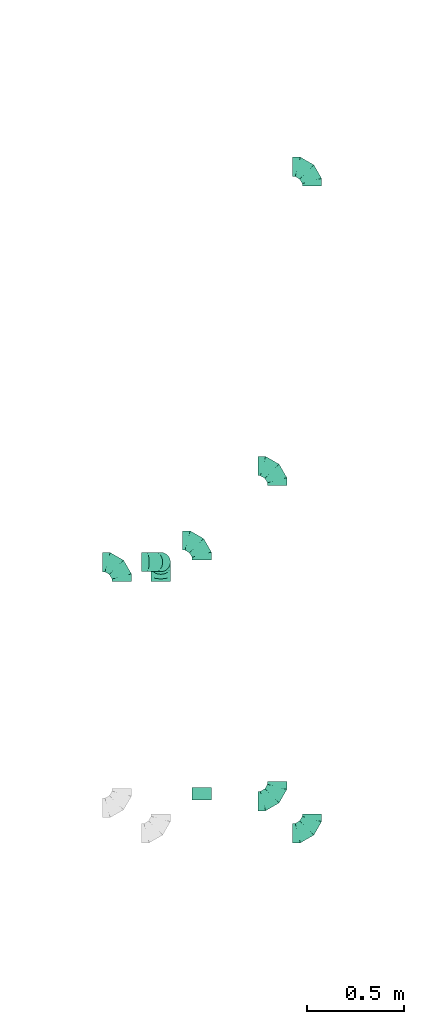
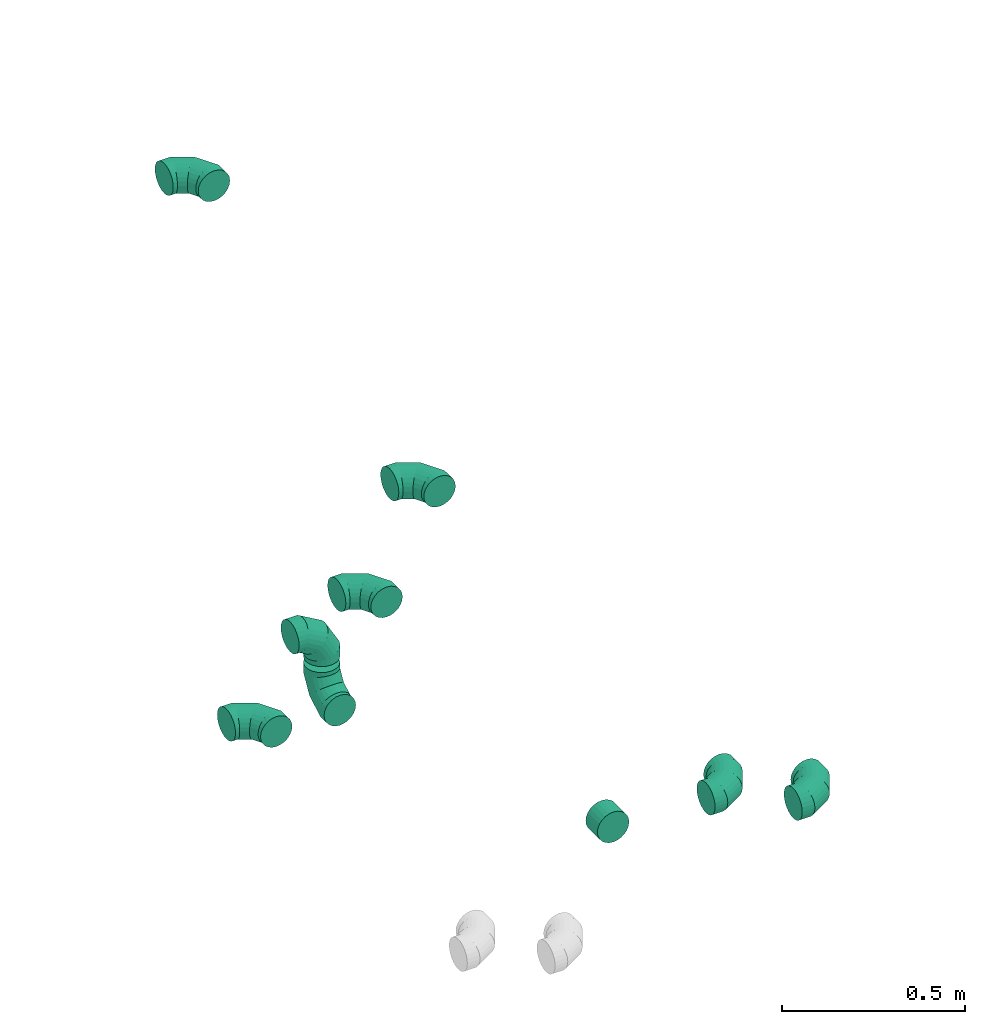
# One storey, part 28 of 32: 9 flow fittings.
"""IFC2X3 building model written with IfcOpenShell, lengths in millimetres."""

import ifcopenshell
import ifcopenshell.guid

model = None  # the IFC model being written
_history = None  # IfcOwnerHistory: only IFC2X3 demands one
_inside = {}  # id of a spatial element -> (the spatial element, [elements in it])
_under = {}  # id of a project, library or spatial element -> (it, [spatial elements below it])
_declared = {}  # id of a project -> (the project, [libraries it declares])
_typed = {}  # id of a type object -> (the type object, [elements of that type])
_made_of = {}  # id of a material, layer set ... -> (it, [elements and type objects made of it])


def new_model(schema):
    """Start an empty IFC model of exactly this schema.

    Asked for "IFC4X3", IfcOpenShell would pick the latest addendum, in which some entities
    have other attributes; the version numbers below select the first issue.
    IFC2X3 requires an IfcOwnerHistory on every rooted entity: one is made here for all.
    """
    global model, _history
    if schema == "IFC4X3":
        model = ifcopenshell.file(schema_version=(4, 3, 0, 0))
    else:
        model = ifcopenshell.file(schema=schema)
    _inside.clear()
    _under.clear()
    _declared.clear()
    _typed.clear()
    _made_of.clear()
    _history = None
    if model.schema == "IFC2X3":
        org = make("IfcOrganization", Name="unknown")
        user = make(
            "IfcPersonAndOrganization",
            ThePerson=make("IfcPerson", FamilyName="unknown"),
            TheOrganization=org,
        )
        app = make(
            "IfcApplication",
            ApplicationDeveloper=org,
            Version="unknown",
            ApplicationFullName="unknown",
            ApplicationIdentifier="unknown",
        )
        _history = make(
            "IfcOwnerHistory",
            OwningUser=user,
            OwningApplication=app,
            ChangeAction="ADDED",
            CreationDate=0,
        )
    return model


def make(cls, **values):
    """One entity of the class cls with the attributes given. An attribute that is None is left unset."""
    return model.create_entity(
        cls, **{name: value for name, value in values.items() if value is not None}
    )


def entity(cls, *values):
    """Any entity or typed value of the class cls, its attributes in the order of the schema. None: left unset."""
    e = model.create_entity(cls)
    for i, value in enumerate(values):
        if value is not None:
            e[i] = value
    return e


def rooted(cls, **values):
    """An entity with a GlobalId (a new one), such as an element, a storey or a relation."""
    return make(cls, GlobalId=ifcopenshell.guid.new(), OwnerHistory=_history, **values)


def si_unit(unit_type, name, prefix=None):
    """IfcSIUnit, for example si_unit("LENGTHUNIT", "METRE", prefix="MILLI")."""
    return make("IfcSIUnit", UnitType=unit_type, Prefix=prefix, Name=name)


def converted_unit(unit_type, name, factor, base, dimensions=None, offset=None):
    """IfcConversionBasedUnit, such as the inch: factor (a typed value) times the base unit."""
    return make(
        "IfcConversionBasedUnit"
        if offset is None
        else "IfcConversionBasedUnitWithOffset",
        ConversionOffset=offset,
        Dimensions=None
        if dimensions is None
        else entity("IfcDimensionalExponents", *dimensions),
        UnitType=unit_type,
        Name=name,
        ConversionFactor=make(
            "IfcMeasureWithUnit", ValueComponent=factor, UnitComponent=base
        ),
    )


def derived_unit(unit_type, elements):
    """IfcDerivedUnit: a product of units, each with its exponent."""
    return make(
        "IfcDerivedUnit",
        Elements=[
            make("IfcDerivedUnitElement", Unit=unit, Exponent=power)
            for unit, power in elements
        ],
        UnitType=unit_type,
    )


def assignment(units):
    """IfcUnitAssignment: the units of a project."""
    return None if units is None else make("IfcUnitAssignment", Units=units)


def point(xyz):
    """IfcCartesianPoint."""
    return None if xyz is None else make("IfcCartesianPoint", Coordinates=xyz)


def direction(xyz):
    """IfcDirection."""
    return None if xyz is None else make("IfcDirection", DirectionRatios=xyz)


def frame(location, z_axis=None, x_axis=None):
    """IfcAxis2Placement3D, a coordinate frame: its origin and axes. An axis left out is left unset."""
    return make(
        "IfcAxis2Placement3D",
        Location=point(location),
        Axis=direction(z_axis),
        RefDirection=direction(x_axis),
    )


def origin():
    """The frame at (0, 0, 0) with its axes left unset."""
    return frame((0.0, 0.0, 0.0))


def place(relative_to, where):
    """IfcLocalPlacement: puts the frame where relative to a parent placement (None: the world)."""
    return make(
        "IfcLocalPlacement", PlacementRelTo=relative_to, RelativePlacement=where
    )


def context(
    kind, dimensions, precision=None, world=None, true_north=None, identifier=None
):
    """IfcGeometricRepresentationContext, for example the 3D "Model" context."""
    return make(
        "IfcGeometricRepresentationContext",
        ContextIdentifier=identifier,
        ContextType=kind,
        CoordinateSpaceDimension=dimensions,
        Precision=precision,
        WorldCoordinateSystem=world,
        TrueNorth=true_north,
    )


def subcontext(parent, identifier, kind, view, scale=None):
    """IfcGeometricRepresentationSubContext, for example "Body" below "Model"."""
    return make(
        "IfcGeometricRepresentationSubContext",
        ContextIdentifier=identifier,
        ContextType=kind,
        ParentContext=parent,
        TargetScale=scale,
        TargetView=view,
    )


def project(units=None, contexts=None):
    """IfcProject with its units and contexts."""
    return rooted(
        "IfcProject",
        Name="project",
        RepresentationContexts=contexts,
        UnitsInContext=assignment(units),
    )


def spatial(cls, under=None, at=None, **own):
    """A site, building, storey or space (cls), placed at a placement, below another one or the project."""
    s = rooted(cls, ObjectPlacement=at, **own)
    if under is not None:
        _under.setdefault(under.id(), (under, []))[1].append(s)
    return s


def faces_of(points, faces, orient=None, outer=None):
    """IfcFace entities. A face is a list of loops; a loop is a list of indices into points, from 0.

    orient and outer hold one flag for each loop. By default every Orientation is true, the
    first loop of a face is its IfcFaceOuterBound and the others are IfcFaceBound.
    """
    made = []
    for i, loops in enumerate(faces):
        bounds = []
        for j, loop in enumerate(loops):
            is_outer = j == 0 if outer is None else outer[i][j]
            bounds.append(
                make(
                    "IfcFaceOuterBound" if is_outer else "IfcFaceBound",
                    Bound=make("IfcPolyLoop", Polygon=[points[k] for k in loop]),
                    Orientation=True if orient is None else orient[i][j],
                )
            )
        made.append(make("IfcFace", Bounds=bounds))
    return made


def faceted_brep(points, faces, orient=None, outer=None, voids=None):
    """IfcFacetedBrep: a solid bounded by flat faces; with voids (closed shells), ...WithVoids."""
    shared = [point(p) for p in points]
    hull = make("IfcClosedShell", CfsFaces=faces_of(shared, faces, orient, outer))
    if voids is None:
        return make("IfcFacetedBrep", Outer=hull)
    return make(
        "IfcFacetedBrepWithVoids",
        Outer=hull,
        Voids=[
            make(cls, CfsFaces=faces_of(shared, fs, o, b)) for cls, fs, o, b in voids
        ],
    )


def shape(context_of_items, identifier, shape_type, items):
    """IfcShapeRepresentation: the items that make up one representation, for example the "Body"."""
    return make(
        "IfcShapeRepresentation",
        ContextOfItems=context_of_items,
        RepresentationIdentifier=identifier,
        RepresentationType=shape_type,
        Items=items,
    )


def source(mapping_origin, context_of_items, identifier, shape_type, items):
    """IfcRepresentationMap: a shape defined once, which mapped items show again and again."""
    return make(
        "IfcRepresentationMap",
        MappingOrigin=mapping_origin,
        MappedRepresentation=shape(context_of_items, identifier, shape_type, items),
    )


def transform(
    local_origin,
    x_axis=None,
    y_axis=None,
    z_axis=None,
    scale=None,
    scale2=None,
    scale3=None,
    uniform=True,
):
    """IfcCartesianTransformationOperator3D, or its non-uniform kind. x_axis, y_axis, z_axis: its Axis1, 2, 3."""
    if uniform:
        return make(
            "IfcCartesianTransformationOperator3D",
            Axis1=direction(x_axis),
            Axis2=direction(y_axis),
            LocalOrigin=point(local_origin),
            Scale=scale,
            Axis3=direction(z_axis),
        )
    return make(
        "IfcCartesianTransformationOperator3DnonUniform",
        Axis1=direction(x_axis),
        Axis2=direction(y_axis),
        LocalOrigin=point(local_origin),
        Scale=scale,
        Axis3=direction(z_axis),
        Scale2=scale2,
        Scale3=scale3,
    )


def mapped(mapping_source, mapping_target):
    """IfcMappedItem: shows the shape of a source again, moved by a transform."""
    return make(
        "IfcMappedItem", MappingSource=mapping_source, MappingTarget=mapping_target
    )


def material(Name=None, Category=None):
    """IfcMaterial."""
    return make("IfcMaterial", Name=Name, Category=Category)


def made_of(thing, what):
    """Note that an element or type object is made of a material, layer set ...; save() writes the relation."""
    if what is not None:
        _made_of.setdefault(what.id(), (what, []))[1].append(thing)
    return thing


def type_object(cls, material=None, **own):
    """A type object (cls), such as IfcWallType, which elements share."""
    return made_of(rooted(cls, **own), material)


def type_shapes(of_type, sources):
    """Give a type object the sources (RepresentationMaps) that its elements show as mapped items."""
    of_type.RepresentationMaps = sources


def element(
    cls,
    number,
    at=None,
    inside=None,
    cuts=None,
    type_object=None,
    material=None,
    context=None,
    identifier="Body",
    shape_type=None,
    held_by="IfcProductDefinitionShape",
    body=None,
    shapes=None,
    **own,
):
    """One element of the class cls, such as IfcWall. Its Tag is "e" and its number.

    at: its placement. inside: the storey or other place that contains it. cuts: it is an
    opening in that element (IfcRelVoidsElement). A single representation is given by context,
    identifier, shape_type and body (its items); several are given by shapes. held_by: the class
    of the entity that holds the representations. save() writes the other relations.
    """
    e = rooted(cls, Tag="e%d" % number, ObjectPlacement=at, **own)
    if body is not None:
        shapes = [shape(context, identifier, shape_type, body)]
    if shapes is not None:
        e.Representation = make(held_by, Representations=shapes)
    if inside is not None:
        _inside.setdefault(inside.id(), (inside, []))[1].append(e)
    if cuts is not None:
        rooted(
            "IfcRelVoidsElement", RelatingBuildingElement=cuts, RelatedOpeningElement=e
        )
    if type_object is not None:
        _typed.setdefault(type_object.id(), (type_object, []))[1].append(e)
    return made_of(e, material)


def aggregate(whole, parts):
    """IfcRelAggregates: a whole, such as a stair, and the parts it consists of."""
    return rooted("IfcRelAggregates", RelatingObject=whole, RelatedObjects=parts)


def save(model, path):
    """Write the relations noted so far, then the file.

    IfcRelAggregates (storeys below a building ...), IfcRelContainedInSpatialStructure (elements
    in a storey), IfcRelDefinesByType, IfcRelAssociatesMaterial and IfcRelDeclares: one each for
    every whole, place, type object, material and project.
    """
    for whole, parts in _under.values():
        aggregate(whole, parts)
    for where, things in _inside.values():
        rooted(
            "IfcRelContainedInSpatialStructure",
            RelatedElements=things,
            RelatingStructure=where,
        )
    for kind, things in _typed.values():
        rooted("IfcRelDefinesByType", RelatedObjects=things, RelatingType=kind)
    for what, things in _made_of.values():
        rooted("IfcRelAssociatesMaterial", RelatedObjects=things, RelatingMaterial=what)
    for by, libraries in _declared.values():
        rooted("IfcRelDeclares", RelatingContext=by, RelatedDefinitions=libraries)
    model.write(path)


model = new_model("IFC2X3")

# Units and contexts
model_context = context("Model", 3, precision=0.01, world=origin(), true_north=direction((6.12303176911189e-17, 1.0)))
body_context = subcontext(model_context, "Body", "Model", "MODEL_VIEW")
ifc_project = project(units=[si_unit("LENGTHUNIT", "METRE", prefix="MILLI"), si_unit("AREAUNIT", "SQUARE_METRE"), si_unit("VOLUMEUNIT", "CUBIC_METRE"), converted_unit("PLANEANGLEUNIT", "DEGREE", entity("IfcRatioMeasure", 0.0174532925199433), si_unit("PLANEANGLEUNIT", "RADIAN"), dimensions=[0, 0, 0, 0, 0, 0, 0]), si_unit("MASSUNIT", "GRAM", prefix="KILO"), derived_unit("MASSDENSITYUNIT", [(si_unit("MASSUNIT", "GRAM", prefix="KILO"), 1), (si_unit("LENGTHUNIT", "METRE"), -3)]), derived_unit("MOMENTOFINERTIAUNIT", [(si_unit("LENGTHUNIT", "METRE"), 4)]), si_unit("TIMEUNIT", "SECOND"), si_unit("FREQUENCYUNIT", "HERTZ"), si_unit("THERMODYNAMICTEMPERATUREUNIT", "DEGREE_CELSIUS"), derived_unit("THERMALTRANSMITTANCEUNIT", [(si_unit("MASSUNIT", "GRAM", prefix="KILO"), 1), (si_unit("THERMODYNAMICTEMPERATUREUNIT", "KELVIN"), -1), (si_unit("TIMEUNIT", "SECOND"), -3)]), derived_unit("VOLUMETRICFLOWRATEUNIT", [(si_unit("LENGTHUNIT", "METRE"), 3), (si_unit("TIMEUNIT", "SECOND"), -1)]), derived_unit("MASSFLOWRATEUNIT", [(si_unit("MASSUNIT", "GRAM", prefix="KILO"), 1), (si_unit("TIMEUNIT", "SECOND"), -1)]), derived_unit("ROTATIONALFREQUENCYUNIT", [(si_unit("TIMEUNIT", "SECOND"), -1)]), si_unit("ELECTRICCURRENTUNIT", "AMPERE"), si_unit("ELECTRICVOLTAGEUNIT", "VOLT"), si_unit("POWERUNIT", "WATT"), si_unit("FORCEUNIT", "NEWTON", prefix="KILO"), si_unit("ILLUMINANCEUNIT", "LUX"), si_unit("LUMINOUSFLUXUNIT", "LUMEN"), si_unit("LUMINOUSINTENSITYUNIT", "CANDELA"), derived_unit("USERDEFINED", [(si_unit("MASSUNIT", "GRAM", prefix="KILO"), -1), (si_unit("LENGTHUNIT", "METRE"), -2), (si_unit("TIMEUNIT", "SECOND"), 3), (si_unit("LUMINOUSFLUXUNIT", "LUMEN"), 1)]), derived_unit("LINEARVELOCITYUNIT", [(si_unit("LENGTHUNIT", "METRE"), 1), (si_unit("TIMEUNIT", "SECOND"), -1)]), si_unit("PRESSUREUNIT", "PASCAL"), derived_unit("USERDEFINED", [(si_unit("LENGTHUNIT", "METRE"), -2), (si_unit("MASSUNIT", "GRAM", prefix="KILO"), 1), (si_unit("TIMEUNIT", "SECOND"), -2)]), derived_unit("LINEARFORCEUNIT", [(si_unit("MASSUNIT", "GRAM", prefix="KILO"), 1), (si_unit("LENGTHUNIT", "METRE"), 1), (si_unit("TIMEUNIT", "SECOND"), -2), (si_unit("LENGTHUNIT", "METRE"), -1)]), derived_unit("PLANARFORCEUNIT", [(si_unit("MASSUNIT", "GRAM", prefix="KILO"), 1), (si_unit("LENGTHUNIT", "METRE"), 1), (si_unit("TIMEUNIT", "SECOND"), -2), (si_unit("LENGTHUNIT", "METRE"), -2)])], contexts=[model_context])

# Site, building, storey
site_placement = place(None, origin())
site = spatial("IfcSite", under=ifc_project, at=site_placement, CompositionType="ELEMENT")
building_placement = place(site_placement, origin())
building = spatial("IfcBuilding", under=site, at=building_placement, CompositionType="ELEMENT")
storey_placement = place(building_placement, frame((0.0, 0.0, 8100.0)))
storey = spatial("IfcBuildingStorey", under=building, at=storey_placement, CompositionType="ELEMENT", Elevation=8100.0)

# Flow fittings
ifc_material = material()
duct_fitting_type_1 = type_object("IfcDuctFittingType", PredefinedType="NOTDEFINED", material=ifc_material)
shared_shape_1 = source(origin(), body_context, "Body", "Brep", [
    faceted_brep([(-100.0, 0.0, -50.0), (-100.0, -12.94, -48.3), (-100.0, -25.0, -43.3), (-100.0, -35.36, -35.36), (-100.0, -43.3, -25.0), (-100.0, -48.3, -12.94), (-100.0, -50.0, 0.0), (-100.0, -48.3, 12.94), (-100.0, -43.3, 25.0), (-100.0, -35.36, 35.36), (-100.0, -25.0, 43.3), (-100.0, -12.94, 48.3), (-100.0, 0.0, 50.0), (-100.0, 12.94, 48.3), (-100.0, 25.0, 43.3), (-100.0, 35.36, 35.36), (-100.0, 43.3, 25.0), (-100.0, 48.3, 12.94), (-100.0, 50.0, 0.0), (-100.0, 48.3, -12.94), (-100.0, 43.3, -25.0), (-100.0, 35.36, -35.36), (-100.0, 25.0, -43.3), (-100.0, 12.94, -48.3), (-76.67, 12.94, 48.3), (-79.9, 25.0, 43.3), (-73.21, 0.0, 50.0), (-82.68, 35.36, 35.36), (-86.15, 48.3, 12.94), (-86.6, 50.0, 0.0), (-84.81, 43.3, 25.0), (-84.81, 43.3, -25.0), (-82.68, 35.36, -35.36), (-86.15, 48.3, -12.94), (-76.67, 12.94, -48.3), (-73.21, 0.0, -50.0), (-79.9, 25.0, -43.3), (-69.74, -12.94, -48.3), (-66.51, -25.0, -43.3), (-63.73, -35.36, -35.36), (-61.6, -43.3, -25.0), (-60.26, -48.3, -12.94), (-59.81, -50.0, 0.0), (-60.26, -48.3, 12.94), (-61.6, -43.3, 25.0), (-63.73, -35.36, 35.36), (-66.51, -25.0, 43.3), (-69.74, -12.94, 48.3), (-36.27, 36.27, 48.3), (-45.1, 45.1, 43.3), (-26.79, 26.79, 50.0), (-52.68, 52.68, 35.36), (-58.49, 58.49, 25.0), (-62.15, 62.15, 12.94), (-63.4, 63.4, 0.0), (-62.15, 62.15, -12.94), (-58.49, 58.49, -25.0), (-52.68, 52.68, -35.36), (-36.27, 36.27, -48.3), (-26.79, 26.79, -50.0), (-45.1, 45.1, -43.3), (-17.32, 17.32, -48.3), (-8.49, 8.49, -43.3), (-0.91, 0.91, -35.36), (4.9, -4.9, -25.0), (8.56, -8.56, -12.94), (9.81, -9.81, 0.0), (8.56, -8.56, 12.94), (4.9, -4.9, 25.0), (-0.91, 0.91, 35.36), (-8.49, 8.49, 43.3), (-17.32, 17.32, 48.3), (-12.94, 76.67, 48.3), (-25.0, 79.9, 43.3), (0.0, 73.21, 50.0), (-35.36, 82.68, 35.36), (-43.3, 84.81, 25.0), (-48.3, 86.15, 12.94), (-50.0, 86.6, 0.0), (-48.3, 86.15, -12.94), (-43.3, 84.81, -25.0), (-35.36, 82.68, -35.36), (-12.94, 76.67, -48.3), (0.0, 73.21, -50.0), (-25.0, 79.9, -43.3), (12.94, 69.74, -48.3), (25.0, 66.51, -43.3), (35.36, 63.73, -35.36), (43.3, 61.6, -25.0), (48.3, 60.26, -12.94), (50.0, 59.81, 0.0), (48.3, 60.26, 12.94), (43.3, 61.6, 25.0), (35.36, 63.73, 35.36), (25.0, 66.51, 43.3), (12.94, 69.74, 48.3), (-12.94, 100.0, -48.3), (-25.0, 100.0, -43.3), (-35.36, 100.0, -35.36), (-43.3, 100.0, -25.0), (-48.3, 100.0, -12.94), (-50.0, 100.0, 0.0), (-48.3, 100.0, 12.94), (-43.3, 100.0, 25.0), (-35.36, 100.0, 35.36), (-25.0, 100.0, 43.3), (-12.94, 100.0, 48.3), (0.0, 100.0, 50.0), (12.94, 100.0, 48.3), (25.0, 100.0, 43.3), (35.36, 100.0, 35.36), (43.3, 100.0, 25.0), (48.3, 100.0, 12.94), (50.0, 100.0, 0.0), (48.3, 100.0, -12.94), (43.3, 100.0, -25.0), (35.36, 100.0, -35.36), (25.0, 100.0, -43.3), (12.94, 100.0, -48.3), (0.0, 100.0, -50.0)], [[[0, 1, 2, 3, 4, 5, 6, 7, 8, 9, 10, 11, 12, 13, 14, 15, 16, 17, 18, 19, 20, 21, 22, 23]], [[24, 25, 14, 13]], [[26, 24, 13, 12]], [[14, 25, 27, 15]], [[28, 29, 18, 17]], [[30, 28, 17, 16]], [[15, 27, 30, 16]], [[20, 31, 32, 21]], [[33, 31, 20, 19]], [[18, 29, 33, 19]], [[34, 35, 0, 23]], [[36, 34, 23, 22]], [[32, 36, 22, 21]], [[2, 1, 37, 38]], [[3, 2, 38, 39]], [[0, 35, 37, 1]], [[5, 4, 40, 41]], [[6, 5, 41, 42]], [[3, 39, 40, 4]], [[6, 42, 43, 7]], [[7, 43, 44, 8]], [[8, 44, 45, 9]], [[10, 46, 47, 11]], [[11, 47, 26, 12]], [[10, 9, 45, 46]], [[48, 49, 25, 24]], [[50, 48, 24, 26]], [[27, 25, 49, 51]], [[52, 53, 28, 30]], [[51, 52, 30, 27]], [[29, 28, 53, 54]], [[55, 56, 31, 33]], [[54, 55, 33, 29]], [[57, 32, 31, 56]], [[58, 59, 35, 34]], [[60, 58, 34, 36]], [[57, 60, 36, 32]], [[37, 35, 59, 61]], [[38, 37, 61, 62]], [[39, 38, 62, 63]], [[41, 40, 64, 65]], [[42, 41, 65, 66]], [[63, 64, 40, 39]], [[43, 42, 66, 67]], [[44, 43, 67, 68]], [[68, 69, 45, 44]], [[46, 45, 69, 70]], [[47, 46, 70, 71]], [[26, 47, 71, 50]], [[72, 73, 49, 48]], [[74, 72, 48, 50]], [[51, 49, 73, 75]], [[76, 77, 53, 52]], [[75, 76, 52, 51]], [[54, 53, 77, 78]], [[79, 80, 56, 55]], [[78, 79, 55, 54]], [[81, 57, 56, 80]], [[82, 83, 59, 58]], [[84, 82, 58, 60]], [[81, 84, 60, 57]], [[61, 59, 83, 85]], [[62, 61, 85, 86]], [[63, 62, 86, 87]], [[65, 64, 88, 89]], [[66, 65, 89, 90]], [[87, 88, 64, 63]], [[67, 66, 90, 91]], [[68, 67, 91, 92]], [[92, 93, 69, 68]], [[70, 69, 93, 94]], [[71, 70, 94, 95]], [[50, 71, 95, 74]], [[96, 97, 98, 99, 100, 101, 102, 103, 104, 105, 106, 107, 108, 109, 110, 111, 112, 113, 114, 115, 116, 117, 118, 119]], [[72, 74, 107, 106]], [[73, 72, 106, 105]], [[75, 73, 105, 104]], [[77, 76, 103, 102]], [[78, 77, 102, 101]], [[75, 104, 103, 76]], [[78, 101, 100, 79]], [[79, 100, 99, 80]], [[80, 99, 98, 81]], [[96, 119, 83, 82]], [[97, 96, 82, 84]], [[84, 81, 98, 97]], [[83, 119, 118, 85]], [[85, 118, 117, 86]], [[86, 117, 116, 87]], [[88, 115, 114, 89]], [[89, 114, 113, 90]], [[87, 116, 115, 88]], [[91, 90, 113, 112]], [[92, 91, 112, 111]], [[93, 92, 111, 110]], [[95, 94, 109, 108]], [[74, 95, 108, 107]], [[110, 109, 94, 93]]]),
])
type_shapes(duct_fitting_type_1, [shared_shape_1])
flow_fitting_1_placement = place(storey_placement, frame((70668.1, 12050.8, 3400.0), z_axis=(0.0, 0.0, 1.0), x_axis=(0.0, 1.0, 0.0)))
element("IfcFlowFitting", 1, at=flow_fitting_1_placement, inside=storey, type_object=duct_fitting_type_1, material=ifc_material, context=body_context, shape_type="MappedRepresentation", body=[
    mapped(shared_shape_1, transform((0.0, 0.0, 0.0), scale=1.0)),
])
for number, where in (
    (2, (70668.1, 10321.33, 3400.0)),
    (3, (70847.71, 10155.6, 3420.0)),
):
    element("IfcFlowFitting", number, at=place(storey_placement, frame(where)), inside=storey, type_object=duct_fitting_type_1, material=ifc_material, context=body_context, shape_type="MappedRepresentation", body=[
        mapped(shared_shape_1, transform((0.0, 0.0, 0.0), scale=1.0)),
    ])
for number, where, z_axis, x_axis in (
    (4, (70847.71, 13595.6, 3420.0), (0.0, 0.0, 1.0), (0.0, 1.0, 0.0)),
    (5, (70278.91, 11666.33, 3400.0), (0.0, 0.0, 1.0), (0.0, 1.0, 0.0)),
    (6, (70067.28, 11555.25, 3400.0), (0.0, 1.0, 0.0), (1.0, 0.0, 0.0)),
    (7, (70067.28, 11555.25, 3180.0), (-1.0, 0.0, 0.0), (0.0, 0.0, -1.0)),
    (8, (69865.78, 11554.29, 3180.0), (0.0, 0.0, 1.0), (0.0, 1.0, 0.0)),
):
    element("IfcFlowFitting", number, at=place(storey_placement, frame(where, z_axis=z_axis, x_axis=x_axis)), inside=storey, type_object=duct_fitting_type_1, material=ifc_material, context=body_context, shape_type="MappedRepresentation", body=[
        mapped(shared_shape_1, transform((0.0, 0.0, 0.0), scale=1.0)),
    ])
duct_fitting_type_2 = type_object("IfcDuctFittingType", PredefinedType="NOTDEFINED", material=ifc_material)
shared_shape_2 = source(origin(), body_context, "Body", "Brep", [
    faceted_brep([(20.0, 12.94, -48.3), (20.0, 25.0, -43.3), (20.0, 35.36, -35.36), (20.0, 43.3, -25.0), (20.0, 48.3, -12.94), (20.0, 50.0, 0.0), (20.0, 48.3, 12.94), (20.0, 43.3, 25.0), (20.0, 35.36, 35.36), (20.0, 25.0, 43.3), (20.0, 12.94, 48.3), (20.0, 0.0, 50.0), (20.0, -12.94, 48.3), (20.0, -25.0, 43.3), (20.0, -35.36, 35.36), (20.0, -43.3, 25.0), (20.0, -48.3, 12.94), (20.0, -50.0, 0.0), (20.0, -48.3, -12.94), (20.0, -43.3, -25.0), (20.0, -35.36, -35.36), (20.0, -25.0, -43.3), (20.0, -12.94, -48.3), (20.0, 0.0, -50.0), (0.0, 0.0, 50.0), (0.0, 12.94, 48.3), (-43.9, 12.94, 48.3), (-43.9, 0.0, 50.0), (0.0, 25.0, 43.3), (-43.9, 25.0, 43.3), (0.0, 35.36, 35.36), (-43.9, 35.36, 35.36), (0.0, 43.3, 25.0), (0.0, 48.3, 12.94), (-43.9, 48.3, 12.94), (-43.9, 43.3, 25.0), (0.0, 50.0, 0.0), (-43.9, 50.0, 0.0), (0.0, 48.3, -12.94), (-43.9, 48.3, -12.94), (0.0, 43.3, -25.0), (-43.9, 43.3, -25.0), (0.0, 35.36, -35.36), (-43.9, 35.36, -35.36), (0.0, 25.0, -43.3), (0.0, 12.94, -48.3), (-43.9, 12.94, -48.3), (-43.9, 25.0, -43.3), (0.0, 0.0, -50.0), (-43.9, 0.0, -50.0), (0.0, -12.94, -48.3), (-43.9, -12.94, -48.3), (0.0, -25.0, -43.3), (-43.9, -25.0, -43.3), (0.0, -35.36, -35.36), (-43.9, -35.36, -35.36), (0.0, -43.3, -25.0), (0.0, -48.3, -12.94), (-43.9, -48.3, -12.94), (-43.9, -43.3, -25.0), (0.0, -50.0, 0.0), (-43.9, -50.0, 0.0), (0.0, -48.3, 12.94), (-43.9, -48.3, 12.94), (0.0, -43.3, 25.0), (-43.9, -43.3, 25.0), (0.0, -35.36, 35.36), (-43.9, -35.36, 35.36), (0.0, -25.0, 43.3), (0.0, -12.94, 48.3), (-43.9, -12.94, 48.3), (-43.9, -25.0, 43.3)], [[[0, 1, 2, 3, 4, 5, 6, 7, 8, 9, 10, 11, 12, 13, 14, 15, 16, 17, 18, 19, 20, 21, 22, 23]], [[24, 11, 10, 25, 26, 27]], [[25, 10, 9, 28, 29, 26]], [[28, 9, 8, 30, 31, 29]], [[32, 7, 6, 33, 34, 35]], [[33, 6, 5, 36, 37, 34]], [[30, 8, 7, 32, 35, 31]], [[36, 5, 4, 38, 39, 37]], [[38, 4, 3, 40, 41, 39]], [[40, 3, 2, 42, 43, 41]], [[44, 1, 0, 45, 46, 47]], [[45, 0, 23, 48, 49, 46]], [[42, 2, 1, 44, 47, 43]], [[48, 23, 22, 50, 51, 49]], [[50, 22, 21, 52, 53, 51]], [[52, 21, 20, 54, 55, 53]], [[56, 19, 18, 57, 58, 59]], [[57, 18, 17, 60, 61, 58]], [[54, 20, 19, 56, 59, 55]], [[60, 17, 16, 62, 63, 61]], [[62, 16, 15, 64, 65, 63]], [[64, 15, 14, 66, 67, 65]], [[68, 13, 12, 69, 70, 71]], [[69, 12, 11, 24, 27, 70]], [[66, 14, 13, 68, 71, 67]], [[49, 51, 53, 55, 59, 58, 61, 63, 65, 67, 71, 70, 27, 26, 29, 31, 35, 34, 37, 39, 41, 43, 47, 46]]]),
])
type_shapes(duct_fitting_type_2, [shared_shape_2])
flow_fitting_2_placement = place(storey_placement, frame((70278.91, 10371.33, 3400.0), z_axis=(0.0, 0.0, -1.0), x_axis=(0.0, 1.0, 0.0)))
element("IfcFlowFitting", 9, at=flow_fitting_2_placement, inside=storey, type_object=duct_fitting_type_2, material=ifc_material, context=body_context, shape_type="MappedRepresentation", body=[
    mapped(shared_shape_2, transform((0.0, 0.0, 0.0), scale=1.0)),
])

save(model, "model.ifc")
